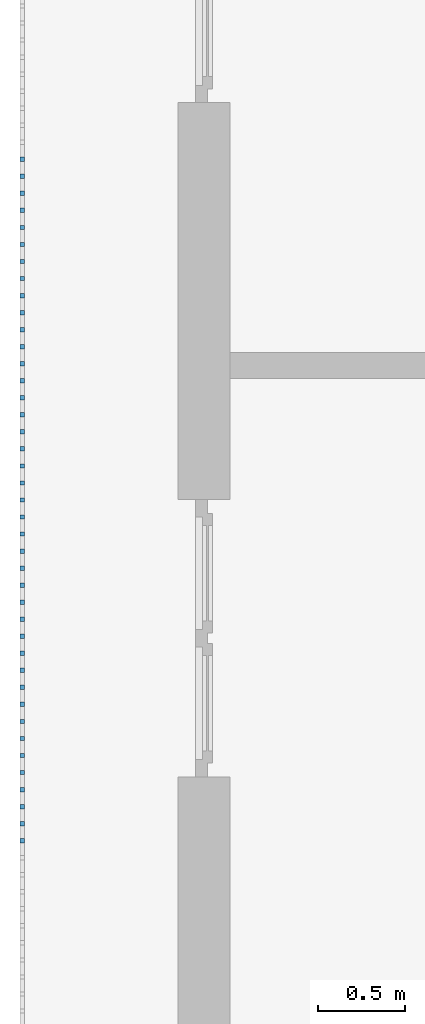
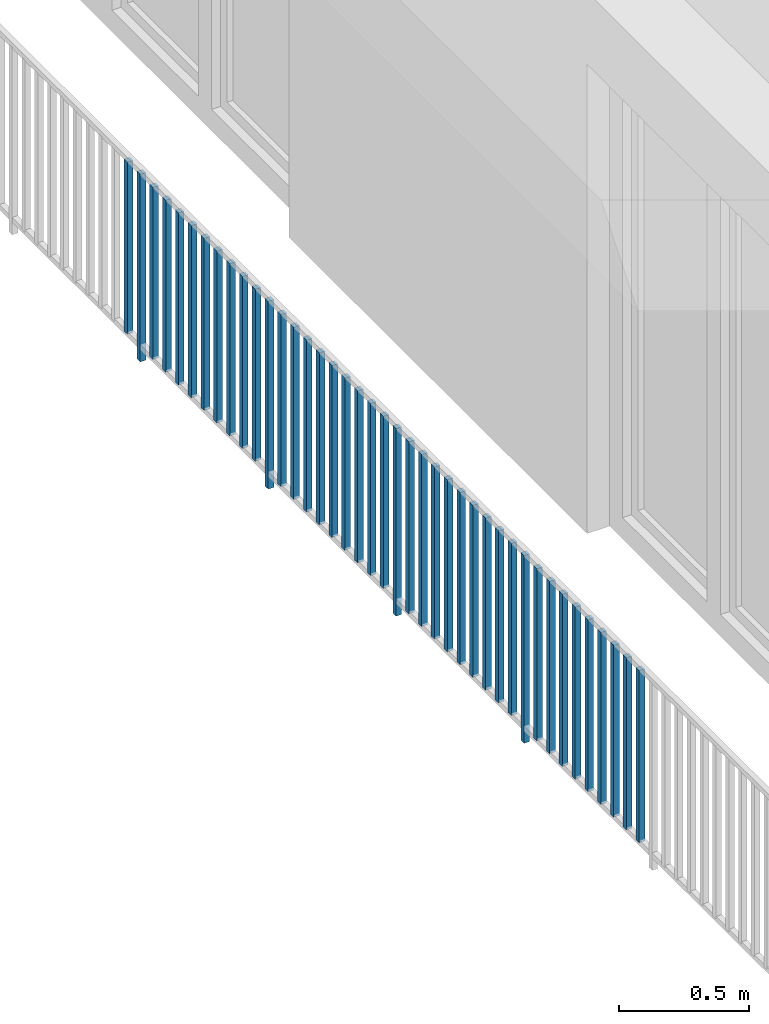
# One storey, part 35 of 54: 41 building element parts, 1 element without a shape of its own.
"""IFC4 building model written with IfcOpenShell, lengths in metres."""

from ifc_helpers import new_model, entity, si_unit, converted_unit, derived_unit, direction, frame, origin_with_axes, place, context, subcontext, project, spatial, polygons, material, type_object, element, aggregate, save


model = new_model("IFC4")

# Units and contexts
model_context = context("Model", 3, precision=1e-05, world=origin_with_axes(), true_north=direction((0.0, 1.0)))
body_context = subcontext(model_context, "Body", "Model", "MODEL_VIEW")
ifc_project = project(units=[si_unit("LENGTHUNIT", "METRE"), si_unit("AREAUNIT", "SQUARE_METRE"), si_unit("VOLUMEUNIT", "CUBIC_METRE"), converted_unit("PLANEANGLEUNIT", "DEGREE", entity("IfcPlaneAngleMeasure", 0.0174532925199), si_unit("PLANEANGLEUNIT", "RADIAN"), dimensions=[0, 0, 0, 0, 0, 0, 0]), converted_unit("TIMEUNIT", "Year", entity("IfcTimeMeasure", 31556926.0), si_unit("TIMEUNIT", "SECOND"), dimensions=[0, 0, 1, 0, 0, 0, 0]), si_unit("MASSUNIT", "GRAM", prefix="KILO"), si_unit("THERMODYNAMICTEMPERATUREUNIT", "DEGREE_CELSIUS"), si_unit("LUMINOUSINTENSITYUNIT", "LUMEN"), si_unit("ENERGYUNIT", "JOULE", prefix="MEGA"), derived_unit("THERMALCONDUCTANCEUNIT", [(si_unit("POWERUNIT", "WATT"), 1), (si_unit("LENGTHUNIT", "METRE"), -1), (si_unit("THERMODYNAMICTEMPERATUREUNIT", "KELVIN"), -1)]), derived_unit("SPECIFICHEATCAPACITYUNIT", [(si_unit("ENERGYUNIT", "JOULE"), 1), (si_unit("MASSUNIT", "GRAM", prefix="KILO"), -1), (si_unit("THERMODYNAMICTEMPERATUREUNIT", "KELVIN"), -1)]), derived_unit("MASSDENSITYUNIT", [(si_unit("MASSUNIT", "GRAM", prefix="KILO"), 1), (si_unit("VOLUMEUNIT", "CUBIC_METRE"), -1)])], contexts=[model_context])

# Site, building, storey, space
site_placement = place(None, origin_with_axes())
site = spatial("IfcSite", under=ifc_project, at=site_placement, CompositionType="ELEMENT")
building_placement = place(site_placement, origin_with_axes())
building = spatial("IfcBuilding", under=site, at=building_placement, CompositionType="ELEMENT")
storey_placement = place(building_placement, frame((0.0, 0.0, 9.18), z_axis=(0.0, 0.0, 1.0), x_axis=(1.0, 0.0, 0.0)))
storey = spatial("IfcBuildingStorey", under=building, at=storey_placement, Name="3. Geschoss", CompositionType="ELEMENT", Elevation=9.18)
space_placement = place(storey_placement, frame((10.2378006196, 9.82118769833, 0.0), z_axis=(0.0, 0.0, 1.0), x_axis=(-1.0, 0.0, 0.0)))
space = spatial("IfcSpace", under=storey, at=space_placement, CompositionType="ELEMENT", PredefinedType="EXTERNAL")

# Railing, building element parts
railing_type = type_object("IfcRailingType", PredefinedType="NOTDEFINED")
railing_placement = place(space_placement, frame((0.0, -7.06315681498e-08, 0.0), z_axis=(0.0, 0.0, 1.0), x_axis=(-1.0, 0.0, 0.0)))
railing = element("IfcRailing", 1, at=railing_placement, inside=space, type_object=railing_type, PredefinedType="NOTDEFINED")
ifc_material = material()
building_element_part_1_placement = place(railing_placement, origin_with_axes())
building_element_part_1 = element("IfcBuildingElementPart", 2, at=building_element_part_1_placement, material=ifc_material, PredefinedType="NOTDEFINED", context=body_context, shape_type="Tessellation", body=[
    polygons([(-22.8925, -12.6975, 0.07), (-22.8675, -12.6975, 0.07), (-22.8675, -12.6975, 0.8775), (-22.8925, -12.6975, 0.8775), (-22.8925, -12.6725, 0.07), (-22.8675, -12.6725, 0.07), (-22.8675, -12.6725, 0.8775), (-22.8925, -12.6725, 0.8775)], [[[1, 2, 3, 4]], [[1, 5, 6, 2]], [[2, 6, 7, 3]], [[4, 3, 7, 8]], [[5, 1, 4, 8]], [[6, 5, 8, 7]]], closed=True),
])
building_element_part_2_placement = place(railing_placement, origin_with_axes())
building_element_part_2 = element("IfcBuildingElementPart", 3, at=building_element_part_2_placement, material=ifc_material, PredefinedType="NOTDEFINED", context=body_context, shape_type="Tessellation", body=[
    polygons([(-22.8925, -12.7958333333, 0.0), (-22.8675, -12.7958333333, 0.0), (-22.8675, -12.7958333333, 0.88), (-22.8925, -12.7958333333, 0.88), (-22.8925, -12.7708333333, 0.0), (-22.8675, -12.7708333333, 0.0), (-22.8675, -12.7708333333, 0.88), (-22.8925, -12.7708333333, 0.88)], [[[1, 2, 3, 4]], [[1, 5, 6, 2]], [[2, 6, 7, 3]], [[4, 3, 7, 8]], [[5, 1, 4, 8]], [[6, 5, 8, 7]]], closed=True),
])
building_element_part_3_placement = place(railing_placement, origin_with_axes())
building_element_part_3 = element("IfcBuildingElementPart", 4, at=building_element_part_3_placement, material=ifc_material, PredefinedType="NOTDEFINED", context=body_context, shape_type="Tessellation", body=[
    polygons([(-22.8925, -12.8941666667, 0.07), (-22.8675, -12.8941666667, 0.07), (-22.8675, -12.8941666667, 0.8775), (-22.8925, -12.8941666667, 0.8775), (-22.8925, -12.8691666667, 0.07), (-22.8675, -12.8691666667, 0.07), (-22.8675, -12.8691666667, 0.8775), (-22.8925, -12.8691666667, 0.8775)], [[[1, 2, 3, 4]], [[1, 5, 6, 2]], [[2, 6, 7, 3]], [[4, 3, 7, 8]], [[5, 1, 4, 8]], [[6, 5, 8, 7]]], closed=True),
])
building_element_part_4_placement = place(railing_placement, origin_with_axes())
building_element_part_4 = element("IfcBuildingElementPart", 5, at=building_element_part_4_placement, material=ifc_material, PredefinedType="NOTDEFINED", context=body_context, shape_type="Tessellation", body=[
    polygons([(-22.8925, -12.9925, 0.07), (-22.8675, -12.9925, 0.07), (-22.8675, -12.9925, 0.8775), (-22.8925, -12.9925, 0.8775), (-22.8925, -12.9675, 0.07), (-22.8675, -12.9675, 0.07), (-22.8675, -12.9675, 0.8775), (-22.8925, -12.9675, 0.8775)], [[[1, 2, 3, 4]], [[1, 5, 6, 2]], [[2, 6, 7, 3]], [[4, 3, 7, 8]], [[5, 1, 4, 8]], [[6, 5, 8, 7]]], closed=True),
])
building_element_part_5_placement = place(railing_placement, origin_with_axes())
building_element_part_5 = element("IfcBuildingElementPart", 6, at=building_element_part_5_placement, material=ifc_material, PredefinedType="NOTDEFINED", context=body_context, shape_type="Tessellation", body=[
    polygons([(-22.8925, -13.0908333333, 0.07), (-22.8675, -13.0908333333, 0.07), (-22.8675, -13.0908333333, 0.8775), (-22.8925, -13.0908333333, 0.8775), (-22.8925, -13.0658333333, 0.07), (-22.8675, -13.0658333333, 0.07), (-22.8675, -13.0658333333, 0.8775), (-22.8925, -13.0658333333, 0.8775)], [[[1, 2, 3, 4]], [[1, 5, 6, 2]], [[2, 6, 7, 3]], [[4, 3, 7, 8]], [[5, 1, 4, 8]], [[6, 5, 8, 7]]], closed=True),
])
building_element_part_6_placement = place(railing_placement, origin_with_axes())
building_element_part_6 = element("IfcBuildingElementPart", 7, at=building_element_part_6_placement, material=ifc_material, PredefinedType="NOTDEFINED", context=body_context, shape_type="Tessellation", body=[
    polygons([(-22.8925, -13.1891666667, 0.07), (-22.8675, -13.1891666667, 0.07), (-22.8675, -13.1891666667, 0.8775), (-22.8925, -13.1891666667, 0.8775), (-22.8925, -13.1641666667, 0.07), (-22.8675, -13.1641666667, 0.07), (-22.8675, -13.1641666667, 0.8775), (-22.8925, -13.1641666667, 0.8775)], [[[1, 2, 3, 4]], [[1, 5, 6, 2]], [[2, 6, 7, 3]], [[4, 3, 7, 8]], [[5, 1, 4, 8]], [[6, 5, 8, 7]]], closed=True),
])
building_element_part_7_placement = place(railing_placement, origin_with_axes())
building_element_part_7 = element("IfcBuildingElementPart", 8, at=building_element_part_7_placement, material=ifc_material, PredefinedType="NOTDEFINED", context=body_context, shape_type="Tessellation", body=[
    polygons([(-22.8925, -13.2875, 0.07), (-22.8675, -13.2875, 0.07), (-22.8675, -13.2875, 0.8775), (-22.8925, -13.2875, 0.8775), (-22.8925, -13.2625, 0.07), (-22.8675, -13.2625, 0.07), (-22.8675, -13.2625, 0.8775), (-22.8925, -13.2625, 0.8775)], [[[1, 2, 3, 4]], [[1, 5, 6, 2]], [[2, 6, 7, 3]], [[4, 3, 7, 8]], [[5, 1, 4, 8]], [[6, 5, 8, 7]]], closed=True),
])
building_element_part_8_placement = place(railing_placement, origin_with_axes())
building_element_part_8 = element("IfcBuildingElementPart", 9, at=building_element_part_8_placement, material=ifc_material, PredefinedType="NOTDEFINED", context=body_context, shape_type="Tessellation", body=[
    polygons([(-22.8925, -13.3858333333, 0.07), (-22.8675, -13.3858333333, 0.07), (-22.8675, -13.3858333333, 0.8775), (-22.8925, -13.3858333333, 0.8775), (-22.8925, -13.3608333333, 0.07), (-22.8675, -13.3608333333, 0.07), (-22.8675, -13.3608333333, 0.8775), (-22.8925, -13.3608333333, 0.8775)], [[[1, 2, 3, 4]], [[1, 5, 6, 2]], [[2, 6, 7, 3]], [[4, 3, 7, 8]], [[5, 1, 4, 8]], [[6, 5, 8, 7]]], closed=True),
])
building_element_part_9_placement = place(railing_placement, origin_with_axes())
building_element_part_9 = element("IfcBuildingElementPart", 10, at=building_element_part_9_placement, material=ifc_material, PredefinedType="NOTDEFINED", context=body_context, shape_type="Tessellation", body=[
    polygons([(-22.8925, -13.4841666667, 0.07), (-22.8675, -13.4841666667, 0.07), (-22.8675, -13.4841666667, 0.8775), (-22.8925, -13.4841666667, 0.8775), (-22.8925, -13.4591666667, 0.07), (-22.8675, -13.4591666667, 0.07), (-22.8675, -13.4591666667, 0.8775), (-22.8925, -13.4591666667, 0.8775)], [[[1, 2, 3, 4]], [[1, 5, 6, 2]], [[2, 6, 7, 3]], [[4, 3, 7, 8]], [[5, 1, 4, 8]], [[6, 5, 8, 7]]], closed=True),
])
building_element_part_10_placement = place(railing_placement, origin_with_axes())
building_element_part_10 = element("IfcBuildingElementPart", 11, at=building_element_part_10_placement, material=ifc_material, PredefinedType="NOTDEFINED", context=body_context, shape_type="Tessellation", body=[
    polygons([(-22.8925, -13.5825, 0.07), (-22.8675, -13.5825, 0.07), (-22.8675, -13.5825, 0.8775), (-22.8925, -13.5825, 0.8775), (-22.8925, -13.5575, 0.07), (-22.8675, -13.5575, 0.07), (-22.8675, -13.5575, 0.8775), (-22.8925, -13.5575, 0.8775)], [[[1, 2, 3, 4]], [[1, 5, 6, 2]], [[2, 6, 7, 3]], [[4, 3, 7, 8]], [[5, 1, 4, 8]], [[6, 5, 8, 7]]], closed=True),
])
building_element_part_11_placement = place(railing_placement, origin_with_axes())
building_element_part_11 = element("IfcBuildingElementPart", 12, at=building_element_part_11_placement, material=ifc_material, PredefinedType="NOTDEFINED", context=body_context, shape_type="Tessellation", body=[
    polygons([(-22.8925, -13.6808333333, 0.07), (-22.8675, -13.6808333333, 0.07), (-22.8675, -13.6808333333, 0.8775), (-22.8925, -13.6808333333, 0.8775), (-22.8925, -13.6558333333, 0.07), (-22.8675, -13.6558333333, 0.07), (-22.8675, -13.6558333333, 0.8775), (-22.8925, -13.6558333333, 0.8775)], [[[1, 2, 3, 4]], [[1, 5, 6, 2]], [[2, 6, 7, 3]], [[4, 3, 7, 8]], [[5, 1, 4, 8]], [[6, 5, 8, 7]]], closed=True),
])
building_element_part_12_placement = place(railing_placement, origin_with_axes())
building_element_part_12 = element("IfcBuildingElementPart", 13, at=building_element_part_12_placement, material=ifc_material, PredefinedType="NOTDEFINED", context=body_context, shape_type="Tessellation", body=[
    polygons([(-22.8925, -13.7791666667, 0.0), (-22.8675, -13.7791666667, 0.0), (-22.8675, -13.7791666667, 0.88), (-22.8925, -13.7791666667, 0.88), (-22.8925, -13.7541666667, 0.0), (-22.8675, -13.7541666667, 0.0), (-22.8675, -13.7541666667, 0.88), (-22.8925, -13.7541666667, 0.88)], [[[1, 2, 3, 4]], [[1, 5, 6, 2]], [[2, 6, 7, 3]], [[4, 3, 7, 8]], [[5, 1, 4, 8]], [[6, 5, 8, 7]]], closed=True),
])
building_element_part_13_placement = place(railing_placement, origin_with_axes())
building_element_part_13 = element("IfcBuildingElementPart", 14, at=building_element_part_13_placement, material=ifc_material, PredefinedType="NOTDEFINED", context=body_context, shape_type="Tessellation", body=[
    polygons([(-22.8925, -13.8775, 0.07), (-22.8675, -13.8775, 0.07), (-22.8675, -13.8775, 0.8775), (-22.8925, -13.8775, 0.8775), (-22.8925, -13.8525, 0.07), (-22.8675, -13.8525, 0.07), (-22.8675, -13.8525, 0.8775), (-22.8925, -13.8525, 0.8775)], [[[1, 2, 3, 4]], [[1, 5, 6, 2]], [[2, 6, 7, 3]], [[4, 3, 7, 8]], [[5, 1, 4, 8]], [[6, 5, 8, 7]]], closed=True),
])
building_element_part_14_placement = place(railing_placement, origin_with_axes())
building_element_part_14 = element("IfcBuildingElementPart", 15, at=building_element_part_14_placement, material=ifc_material, PredefinedType="NOTDEFINED", context=body_context, shape_type="Tessellation", body=[
    polygons([(-22.8925, -13.9758333333, 0.07), (-22.8675, -13.9758333333, 0.07), (-22.8675, -13.9758333333, 0.8775), (-22.8925, -13.9758333333, 0.8775), (-22.8925, -13.9508333333, 0.07), (-22.8675, -13.9508333333, 0.07), (-22.8675, -13.9508333333, 0.8775), (-22.8925, -13.9508333333, 0.8775)], [[[1, 2, 3, 4]], [[1, 5, 6, 2]], [[2, 6, 7, 3]], [[4, 3, 7, 8]], [[5, 1, 4, 8]], [[6, 5, 8, 7]]], closed=True),
])
building_element_part_15_placement = place(railing_placement, origin_with_axes())
building_element_part_15 = element("IfcBuildingElementPart", 16, at=building_element_part_15_placement, material=ifc_material, PredefinedType="NOTDEFINED", context=body_context, shape_type="Tessellation", body=[
    polygons([(-22.8925, -14.0741666667, 0.07), (-22.8675, -14.0741666667, 0.07), (-22.8675, -14.0741666667, 0.8775), (-22.8925, -14.0741666667, 0.8775), (-22.8925, -14.0491666667, 0.07), (-22.8675, -14.0491666667, 0.07), (-22.8675, -14.0491666667, 0.8775), (-22.8925, -14.0491666667, 0.8775)], [[[1, 2, 3, 4]], [[1, 5, 6, 2]], [[2, 6, 7, 3]], [[4, 3, 7, 8]], [[5, 1, 4, 8]], [[6, 5, 8, 7]]], closed=True),
])
building_element_part_16_placement = place(railing_placement, origin_with_axes())
building_element_part_16 = element("IfcBuildingElementPart", 17, at=building_element_part_16_placement, material=ifc_material, PredefinedType="NOTDEFINED", context=body_context, shape_type="Tessellation", body=[
    polygons([(-22.8925, -14.1725, 0.07), (-22.8675, -14.1725, 0.07), (-22.8675, -14.1725, 0.8775), (-22.8925, -14.1725, 0.8775), (-22.8925, -14.1475, 0.07), (-22.8675, -14.1475, 0.07), (-22.8675, -14.1475, 0.8775), (-22.8925, -14.1475, 0.8775)], [[[1, 2, 3, 4]], [[1, 5, 6, 2]], [[2, 6, 7, 3]], [[4, 3, 7, 8]], [[5, 1, 4, 8]], [[6, 5, 8, 7]]], closed=True),
])
building_element_part_17_placement = place(railing_placement, origin_with_axes())
building_element_part_17 = element("IfcBuildingElementPart", 18, at=building_element_part_17_placement, material=ifc_material, PredefinedType="NOTDEFINED", context=body_context, shape_type="Tessellation", body=[
    polygons([(-22.8925, -14.2708333333, 0.07), (-22.8675, -14.2708333333, 0.07), (-22.8675, -14.2708333333, 0.8775), (-22.8925, -14.2708333333, 0.8775), (-22.8925, -14.2458333333, 0.07), (-22.8675, -14.2458333333, 0.07), (-22.8675, -14.2458333333, 0.8775), (-22.8925, -14.2458333333, 0.8775)], [[[1, 2, 3, 4]], [[1, 5, 6, 2]], [[2, 6, 7, 3]], [[4, 3, 7, 8]], [[5, 1, 4, 8]], [[6, 5, 8, 7]]], closed=True),
])
building_element_part_18_placement = place(railing_placement, origin_with_axes())
building_element_part_18 = element("IfcBuildingElementPart", 19, at=building_element_part_18_placement, material=ifc_material, PredefinedType="NOTDEFINED", context=body_context, shape_type="Tessellation", body=[
    polygons([(-22.8925, -14.3691666667, 0.07), (-22.8675, -14.3691666667, 0.07), (-22.8675, -14.3691666667, 0.8775), (-22.8925, -14.3691666667, 0.8775), (-22.8925, -14.3441666667, 0.07), (-22.8675, -14.3441666667, 0.07), (-22.8675, -14.3441666667, 0.8775), (-22.8925, -14.3441666667, 0.8775)], [[[1, 2, 3, 4]], [[1, 5, 6, 2]], [[2, 6, 7, 3]], [[4, 3, 7, 8]], [[5, 1, 4, 8]], [[6, 5, 8, 7]]], closed=True),
])
building_element_part_19_placement = place(railing_placement, origin_with_axes())
building_element_part_19 = element("IfcBuildingElementPart", 20, at=building_element_part_19_placement, material=ifc_material, PredefinedType="NOTDEFINED", context=body_context, shape_type="Tessellation", body=[
    polygons([(-22.8925, -14.4675, 0.07), (-22.8675, -14.4675, 0.07), (-22.8675, -14.4675, 0.8775), (-22.8925, -14.4675, 0.8775), (-22.8925, -14.4425, 0.07), (-22.8675, -14.4425, 0.07), (-22.8675, -14.4425, 0.8775), (-22.8925, -14.4425, 0.8775)], [[[1, 2, 3, 4]], [[1, 5, 6, 2]], [[2, 6, 7, 3]], [[4, 3, 7, 8]], [[5, 1, 4, 8]], [[6, 5, 8, 7]]], closed=True),
])
building_element_part_20_placement = place(railing_placement, origin_with_axes())
building_element_part_20 = element("IfcBuildingElementPart", 21, at=building_element_part_20_placement, material=ifc_material, PredefinedType="NOTDEFINED", context=body_context, shape_type="Tessellation", body=[
    polygons([(-22.8925, -14.5658333333, 0.07), (-22.8675, -14.5658333333, 0.07), (-22.8675, -14.5658333333, 0.8775), (-22.8925, -14.5658333333, 0.8775), (-22.8925, -14.5408333333, 0.07), (-22.8675, -14.5408333333, 0.07), (-22.8675, -14.5408333333, 0.8775), (-22.8925, -14.5408333333, 0.8775)], [[[1, 2, 3, 4]], [[1, 5, 6, 2]], [[2, 6, 7, 3]], [[4, 3, 7, 8]], [[5, 1, 4, 8]], [[6, 5, 8, 7]]], closed=True),
])
building_element_part_21_placement = place(railing_placement, origin_with_axes())
building_element_part_21 = element("IfcBuildingElementPart", 22, at=building_element_part_21_placement, material=ifc_material, PredefinedType="NOTDEFINED", context=body_context, shape_type="Tessellation", body=[
    polygons([(-22.8925, -14.6641666667, 0.07), (-22.8675, -14.6641666667, 0.07), (-22.8675, -14.6641666667, 0.8775), (-22.8925, -14.6641666667, 0.8775), (-22.8925, -14.6391666667, 0.07), (-22.8675, -14.6391666667, 0.07), (-22.8675, -14.6391666667, 0.8775), (-22.8925, -14.6391666667, 0.8775)], [[[1, 2, 3, 4]], [[1, 5, 6, 2]], [[2, 6, 7, 3]], [[4, 3, 7, 8]], [[5, 1, 4, 8]], [[6, 5, 8, 7]]], closed=True),
])
building_element_part_22_placement = place(railing_placement, origin_with_axes())
building_element_part_22 = element("IfcBuildingElementPart", 23, at=building_element_part_22_placement, material=ifc_material, PredefinedType="NOTDEFINED", context=body_context, shape_type="Tessellation", body=[
    polygons([(-22.8925, -14.7625, 0.0), (-22.8675, -14.7625, 0.0), (-22.8675, -14.7625, 0.88), (-22.8925, -14.7625, 0.88), (-22.8925, -14.7375, 0.0), (-22.8675, -14.7375, 0.0), (-22.8675, -14.7375, 0.88), (-22.8925, -14.7375, 0.88)], [[[1, 2, 3, 4]], [[1, 5, 6, 2]], [[2, 6, 7, 3]], [[4, 3, 7, 8]], [[5, 1, 4, 8]], [[6, 5, 8, 7]]], closed=True),
])
building_element_part_23_placement = place(railing_placement, origin_with_axes())
building_element_part_23 = element("IfcBuildingElementPart", 24, at=building_element_part_23_placement, material=ifc_material, PredefinedType="NOTDEFINED", context=body_context, shape_type="Tessellation", body=[
    polygons([(-22.8925, -14.8608333333, 0.07), (-22.8675, -14.8608333333, 0.07), (-22.8675, -14.8608333333, 0.8775), (-22.8925, -14.8608333333, 0.8775), (-22.8925, -14.8358333333, 0.07), (-22.8675, -14.8358333333, 0.07), (-22.8675, -14.8358333333, 0.8775), (-22.8925, -14.8358333333, 0.8775)], [[[1, 2, 3, 4]], [[1, 5, 6, 2]], [[2, 6, 7, 3]], [[4, 3, 7, 8]], [[5, 1, 4, 8]], [[6, 5, 8, 7]]], closed=True),
])
building_element_part_24_placement = place(railing_placement, origin_with_axes())
building_element_part_24 = element("IfcBuildingElementPart", 25, at=building_element_part_24_placement, material=ifc_material, PredefinedType="NOTDEFINED", context=body_context, shape_type="Tessellation", body=[
    polygons([(-22.8925, -14.9591666667, 0.07), (-22.8675, -14.9591666667, 0.07), (-22.8675, -14.9591666667, 0.8775), (-22.8925, -14.9591666667, 0.8775), (-22.8925, -14.9341666667, 0.07), (-22.8675, -14.9341666667, 0.07), (-22.8675, -14.9341666667, 0.8775), (-22.8925, -14.9341666667, 0.8775)], [[[1, 2, 3, 4]], [[1, 5, 6, 2]], [[2, 6, 7, 3]], [[4, 3, 7, 8]], [[5, 1, 4, 8]], [[6, 5, 8, 7]]], closed=True),
])
building_element_part_25_placement = place(railing_placement, origin_with_axes())
building_element_part_25 = element("IfcBuildingElementPart", 26, at=building_element_part_25_placement, material=ifc_material, PredefinedType="NOTDEFINED", context=body_context, shape_type="Tessellation", body=[
    polygons([(-22.8925, -15.0575, 0.07), (-22.8675, -15.0575, 0.07), (-22.8675, -15.0575, 0.8775), (-22.8925, -15.0575, 0.8775), (-22.8925, -15.0325, 0.07), (-22.8675, -15.0325, 0.07), (-22.8675, -15.0325, 0.8775), (-22.8925, -15.0325, 0.8775)], [[[1, 2, 3, 4]], [[1, 5, 6, 2]], [[2, 6, 7, 3]], [[4, 3, 7, 8]], [[5, 1, 4, 8]], [[6, 5, 8, 7]]], closed=True),
])
building_element_part_26_placement = place(railing_placement, origin_with_axes())
building_element_part_26 = element("IfcBuildingElementPart", 27, at=building_element_part_26_placement, material=ifc_material, PredefinedType="NOTDEFINED", context=body_context, shape_type="Tessellation", body=[
    polygons([(-22.8925, -15.1558333333, 0.07), (-22.8675, -15.1558333333, 0.07), (-22.8675, -15.1558333333, 0.8775), (-22.8925, -15.1558333333, 0.8775), (-22.8925, -15.1308333333, 0.07), (-22.8675, -15.1308333333, 0.07), (-22.8675, -15.1308333333, 0.8775), (-22.8925, -15.1308333333, 0.8775)], [[[1, 2, 3, 4]], [[1, 5, 6, 2]], [[2, 6, 7, 3]], [[4, 3, 7, 8]], [[5, 1, 4, 8]], [[6, 5, 8, 7]]], closed=True),
])
building_element_part_27_placement = place(railing_placement, origin_with_axes())
building_element_part_27 = element("IfcBuildingElementPart", 28, at=building_element_part_27_placement, material=ifc_material, PredefinedType="NOTDEFINED", context=body_context, shape_type="Tessellation", body=[
    polygons([(-22.8925, -15.2541666667, 0.07), (-22.8675, -15.2541666667, 0.07), (-22.8675, -15.2541666667, 0.8775), (-22.8925, -15.2541666667, 0.8775), (-22.8925, -15.2291666667, 0.07), (-22.8675, -15.2291666667, 0.07), (-22.8675, -15.2291666667, 0.8775), (-22.8925, -15.2291666667, 0.8775)], [[[1, 2, 3, 4]], [[1, 5, 6, 2]], [[2, 6, 7, 3]], [[4, 3, 7, 8]], [[5, 1, 4, 8]], [[6, 5, 8, 7]]], closed=True),
])
building_element_part_28_placement = place(railing_placement, origin_with_axes())
building_element_part_28 = element("IfcBuildingElementPart", 29, at=building_element_part_28_placement, material=ifc_material, PredefinedType="NOTDEFINED", context=body_context, shape_type="Tessellation", body=[
    polygons([(-22.8925, -15.3525, 0.07), (-22.8675, -15.3525, 0.07), (-22.8675, -15.3525, 0.8775), (-22.8925, -15.3525, 0.8775), (-22.8925, -15.3275, 0.07), (-22.8675, -15.3275, 0.07), (-22.8675, -15.3275, 0.8775), (-22.8925, -15.3275, 0.8775)], [[[1, 2, 3, 4]], [[1, 5, 6, 2]], [[2, 6, 7, 3]], [[4, 3, 7, 8]], [[5, 1, 4, 8]], [[6, 5, 8, 7]]], closed=True),
])
building_element_part_29_placement = place(railing_placement, origin_with_axes())
building_element_part_29 = element("IfcBuildingElementPart", 30, at=building_element_part_29_placement, material=ifc_material, PredefinedType="NOTDEFINED", context=body_context, shape_type="Tessellation", body=[
    polygons([(-22.8925, -15.4508333333, 0.07), (-22.8675, -15.4508333333, 0.07), (-22.8675, -15.4508333333, 0.8775), (-22.8925, -15.4508333333, 0.8775), (-22.8925, -15.4258333333, 0.07), (-22.8675, -15.4258333333, 0.07), (-22.8675, -15.4258333333, 0.8775), (-22.8925, -15.4258333333, 0.8775)], [[[1, 2, 3, 4]], [[1, 5, 6, 2]], [[2, 6, 7, 3]], [[4, 3, 7, 8]], [[5, 1, 4, 8]], [[6, 5, 8, 7]]], closed=True),
])
building_element_part_30_placement = place(railing_placement, origin_with_axes())
building_element_part_30 = element("IfcBuildingElementPart", 31, at=building_element_part_30_placement, material=ifc_material, PredefinedType="NOTDEFINED", context=body_context, shape_type="Tessellation", body=[
    polygons([(-22.8925, -15.5491666667, 0.07), (-22.8675, -15.5491666667, 0.07), (-22.8675, -15.5491666667, 0.8775), (-22.8925, -15.5491666667, 0.8775), (-22.8925, -15.5241666667, 0.07), (-22.8675, -15.5241666667, 0.07), (-22.8675, -15.5241666667, 0.8775), (-22.8925, -15.5241666667, 0.8775)], [[[1, 2, 3, 4]], [[1, 5, 6, 2]], [[2, 6, 7, 3]], [[4, 3, 7, 8]], [[5, 1, 4, 8]], [[6, 5, 8, 7]]], closed=True),
])
building_element_part_31_placement = place(railing_placement, origin_with_axes())
building_element_part_31 = element("IfcBuildingElementPart", 32, at=building_element_part_31_placement, material=ifc_material, PredefinedType="NOTDEFINED", context=body_context, shape_type="Tessellation", body=[
    polygons([(-22.8925, -15.6475, 0.07), (-22.8675, -15.6475, 0.07), (-22.8675, -15.6475, 0.8775), (-22.8925, -15.6475, 0.8775), (-22.8925, -15.6225, 0.07), (-22.8675, -15.6225, 0.07), (-22.8675, -15.6225, 0.8775), (-22.8925, -15.6225, 0.8775)], [[[1, 2, 3, 4]], [[1, 5, 6, 2]], [[2, 6, 7, 3]], [[4, 3, 7, 8]], [[5, 1, 4, 8]], [[6, 5, 8, 7]]], closed=True),
])
building_element_part_32_placement = place(railing_placement, origin_with_axes())
building_element_part_32 = element("IfcBuildingElementPart", 33, at=building_element_part_32_placement, material=ifc_material, PredefinedType="NOTDEFINED", context=body_context, shape_type="Tessellation", body=[
    polygons([(-22.8925, -15.7458333333, 0.0), (-22.8675, -15.7458333333, 0.0), (-22.8675, -15.7458333333, 0.88), (-22.8925, -15.7458333333, 0.88), (-22.8925, -15.7208333333, 0.0), (-22.8675, -15.7208333333, 0.0), (-22.8675, -15.7208333333, 0.88), (-22.8925, -15.7208333333, 0.88)], [[[1, 2, 3, 4]], [[1, 5, 6, 2]], [[2, 6, 7, 3]], [[4, 3, 7, 8]], [[5, 1, 4, 8]], [[6, 5, 8, 7]]], closed=True),
])
building_element_part_33_placement = place(railing_placement, origin_with_axes())
building_element_part_33 = element("IfcBuildingElementPart", 34, at=building_element_part_33_placement, material=ifc_material, PredefinedType="NOTDEFINED", context=body_context, shape_type="Tessellation", body=[
    polygons([(-22.8925, -15.8441666667, 0.07), (-22.8675, -15.8441666667, 0.07), (-22.8675, -15.8441666667, 0.8775), (-22.8925, -15.8441666667, 0.8775), (-22.8925, -15.8191666667, 0.07), (-22.8675, -15.8191666667, 0.07), (-22.8675, -15.8191666667, 0.8775), (-22.8925, -15.8191666667, 0.8775)], [[[1, 2, 3, 4]], [[1, 5, 6, 2]], [[2, 6, 7, 3]], [[4, 3, 7, 8]], [[5, 1, 4, 8]], [[6, 5, 8, 7]]], closed=True),
])
building_element_part_34_placement = place(railing_placement, origin_with_axes())
building_element_part_34 = element("IfcBuildingElementPart", 35, at=building_element_part_34_placement, material=ifc_material, PredefinedType="NOTDEFINED", context=body_context, shape_type="Tessellation", body=[
    polygons([(-22.8925, -15.9425, 0.07), (-22.8675, -15.9425, 0.07), (-22.8675, -15.9425, 0.8775), (-22.8925, -15.9425, 0.8775), (-22.8925, -15.9175, 0.07), (-22.8675, -15.9175, 0.07), (-22.8675, -15.9175, 0.8775), (-22.8925, -15.9175, 0.8775)], [[[1, 2, 3, 4]], [[1, 5, 6, 2]], [[2, 6, 7, 3]], [[4, 3, 7, 8]], [[5, 1, 4, 8]], [[6, 5, 8, 7]]], closed=True),
])
building_element_part_35_placement = place(railing_placement, origin_with_axes())
building_element_part_35 = element("IfcBuildingElementPart", 36, at=building_element_part_35_placement, material=ifc_material, PredefinedType="NOTDEFINED", context=body_context, shape_type="Tessellation", body=[
    polygons([(-22.8925, -16.0408333333, 0.07), (-22.8675, -16.0408333333, 0.07), (-22.8675, -16.0408333333, 0.8775), (-22.8925, -16.0408333333, 0.8775), (-22.8925, -16.0158333333, 0.07), (-22.8675, -16.0158333333, 0.07), (-22.8675, -16.0158333333, 0.8775), (-22.8925, -16.0158333333, 0.8775)], [[[1, 2, 3, 4]], [[1, 5, 6, 2]], [[2, 6, 7, 3]], [[4, 3, 7, 8]], [[5, 1, 4, 8]], [[6, 5, 8, 7]]], closed=True),
])
building_element_part_36_placement = place(railing_placement, origin_with_axes())
building_element_part_36 = element("IfcBuildingElementPart", 37, at=building_element_part_36_placement, material=ifc_material, PredefinedType="NOTDEFINED", context=body_context, shape_type="Tessellation", body=[
    polygons([(-22.8925, -16.1391666667, 0.07), (-22.8675, -16.1391666667, 0.07), (-22.8675, -16.1391666667, 0.8775), (-22.8925, -16.1391666667, 0.8775), (-22.8925, -16.1141666667, 0.07), (-22.8675, -16.1141666667, 0.07), (-22.8675, -16.1141666667, 0.8775), (-22.8925, -16.1141666667, 0.8775)], [[[1, 2, 3, 4]], [[1, 5, 6, 2]], [[2, 6, 7, 3]], [[4, 3, 7, 8]], [[5, 1, 4, 8]], [[6, 5, 8, 7]]], closed=True),
])
building_element_part_37_placement = place(railing_placement, origin_with_axes())
building_element_part_37 = element("IfcBuildingElementPart", 38, at=building_element_part_37_placement, material=ifc_material, PredefinedType="NOTDEFINED", context=body_context, shape_type="Tessellation", body=[
    polygons([(-22.8925, -16.2375, 0.07), (-22.8675, -16.2375, 0.07), (-22.8675, -16.2375, 0.8775), (-22.8925, -16.2375, 0.8775), (-22.8925, -16.2125, 0.07), (-22.8675, -16.2125, 0.07), (-22.8675, -16.2125, 0.8775), (-22.8925, -16.2125, 0.8775)], [[[1, 2, 3, 4]], [[1, 5, 6, 2]], [[2, 6, 7, 3]], [[4, 3, 7, 8]], [[5, 1, 4, 8]], [[6, 5, 8, 7]]], closed=True),
])
building_element_part_38_placement = place(railing_placement, origin_with_axes())
building_element_part_38 = element("IfcBuildingElementPart", 39, at=building_element_part_38_placement, material=ifc_material, PredefinedType="NOTDEFINED", context=body_context, shape_type="Tessellation", body=[
    polygons([(-22.8925, -16.3358333333, 0.07), (-22.8675, -16.3358333333, 0.07), (-22.8675, -16.3358333333, 0.8775), (-22.8925, -16.3358333333, 0.8775), (-22.8925, -16.3108333333, 0.07), (-22.8675, -16.3108333333, 0.07), (-22.8675, -16.3108333333, 0.8775), (-22.8925, -16.3108333333, 0.8775)], [[[1, 2, 3, 4]], [[1, 5, 6, 2]], [[2, 6, 7, 3]], [[4, 3, 7, 8]], [[5, 1, 4, 8]], [[6, 5, 8, 7]]], closed=True),
])
building_element_part_39_placement = place(railing_placement, origin_with_axes())
building_element_part_39 = element("IfcBuildingElementPart", 40, at=building_element_part_39_placement, material=ifc_material, PredefinedType="NOTDEFINED", context=body_context, shape_type="Tessellation", body=[
    polygons([(-22.8925, -16.4341666667, 0.07), (-22.8675, -16.4341666667, 0.07), (-22.8675, -16.4341666667, 0.8775), (-22.8925, -16.4341666667, 0.8775), (-22.8925, -16.4091666667, 0.07), (-22.8675, -16.4091666667, 0.07), (-22.8675, -16.4091666667, 0.8775), (-22.8925, -16.4091666667, 0.8775)], [[[1, 2, 3, 4]], [[1, 5, 6, 2]], [[2, 6, 7, 3]], [[4, 3, 7, 8]], [[5, 1, 4, 8]], [[6, 5, 8, 7]]], closed=True),
])
building_element_part_40_placement = place(railing_placement, origin_with_axes())
building_element_part_40 = element("IfcBuildingElementPart", 41, at=building_element_part_40_placement, material=ifc_material, PredefinedType="NOTDEFINED", context=body_context, shape_type="Tessellation", body=[
    polygons([(-22.8925, -16.5325, 0.07), (-22.8675, -16.5325, 0.07), (-22.8675, -16.5325, 0.8775), (-22.8925, -16.5325, 0.8775), (-22.8925, -16.5075, 0.07), (-22.8675, -16.5075, 0.07), (-22.8675, -16.5075, 0.8775), (-22.8925, -16.5075, 0.8775)], [[[1, 2, 3, 4]], [[1, 5, 6, 2]], [[2, 6, 7, 3]], [[4, 3, 7, 8]], [[5, 1, 4, 8]], [[6, 5, 8, 7]]], closed=True),
])
building_element_part_41_placement = place(railing_placement, origin_with_axes())
building_element_part_41 = element("IfcBuildingElementPart", 42, at=building_element_part_41_placement, material=ifc_material, PredefinedType="NOTDEFINED", context=body_context, shape_type="Tessellation", body=[
    polygons([(-22.8925, -16.6308333333, 0.07), (-22.8675, -16.6308333333, 0.07), (-22.8675, -16.6308333333, 0.8775), (-22.8925, -16.6308333333, 0.8775), (-22.8925, -16.6058333333, 0.07), (-22.8675, -16.6058333333, 0.07), (-22.8675, -16.6058333333, 0.8775), (-22.8925, -16.6058333333, 0.8775)], [[[1, 2, 3, 4]], [[1, 5, 6, 2]], [[2, 6, 7, 3]], [[4, 3, 7, 8]], [[5, 1, 4, 8]], [[6, 5, 8, 7]]], closed=True),
])
aggregate(railing, [building_element_part_1, building_element_part_2, building_element_part_3, building_element_part_4, building_element_part_5, building_element_part_6, building_element_part_7, building_element_part_8, building_element_part_9, building_element_part_10, building_element_part_11, building_element_part_12, building_element_part_13, building_element_part_14, building_element_part_15, building_element_part_16, building_element_part_17, building_element_part_18, building_element_part_19, building_element_part_20, building_element_part_21, building_element_part_22, building_element_part_23, building_element_part_24, building_element_part_25, building_element_part_26, building_element_part_27, building_element_part_28, building_element_part_29, building_element_part_30, building_element_part_31, building_element_part_32, building_element_part_33, building_element_part_34, building_element_part_35, building_element_part_36, building_element_part_37, building_element_part_38, building_element_part_39, building_element_part_40, building_element_part_41])

save(model, "model.ifc")
